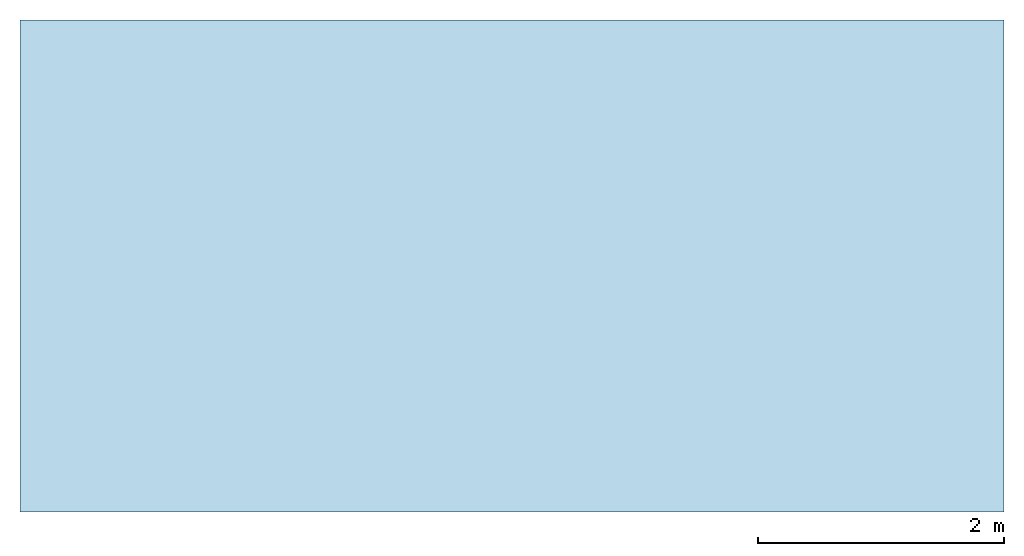
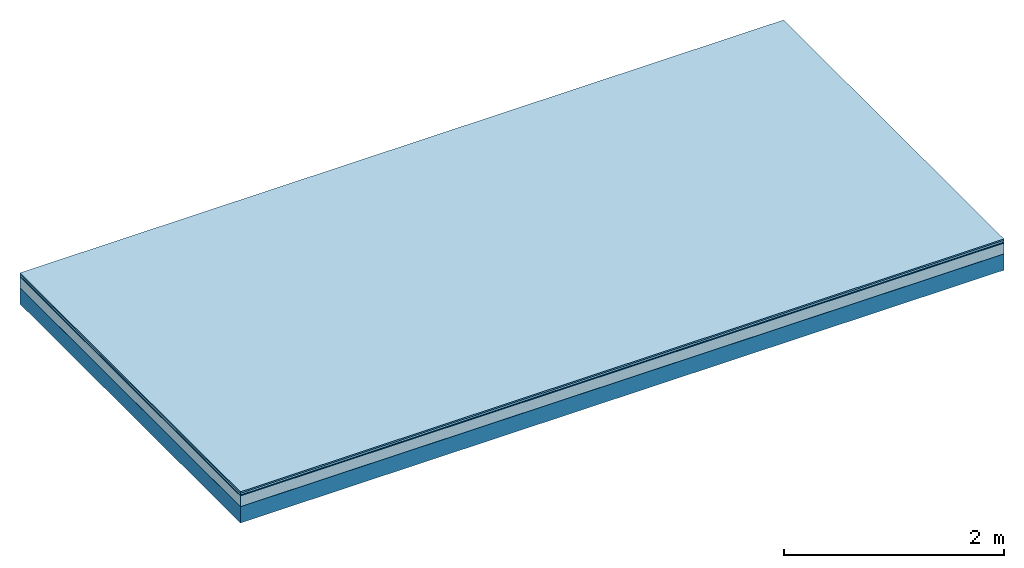
# One storey: 5 plates, 1 member, 1 element without a shape of its own.
"""IFC4 building model written with IfcOpenShell, lengths in metres."""

from ifc_helpers import new_model, si_unit, derived_unit, direction, frame, frame_2d, origin, origin_with_axes, place, context, project, spatial, rectangle, extrude, material, layer, layer_set, type_object, element, aggregate, save


model = new_model("IFC4")

# Units and contexts
plan_context = context("Plan", 3, precision=1e-05, world=origin(), true_north=direction((0.0, 1.0)))
model_context = context("Model", 3, precision=1e-05, world=origin(), true_north=direction((0.0, 1.0)))
ifc_project = project(units=[si_unit("LENGTHUNIT", "METRE"), derived_unit("SOUNDPRESSUREUNIT", [(si_unit("PRESSUREUNIT", "PASCAL", prefix="MICRO"), 0)]), si_unit("ENERGYUNIT", "JOULE", prefix="MEGA"), si_unit("MASSUNIT", "GRAM", prefix="KILO"), derived_unit("THERMALTRANSMITTANCEUNIT", [(si_unit("POWERUNIT", "WATT"), 1), (si_unit("AREAUNIT", "SQUARE_METRE"), -1), (si_unit("THERMODYNAMICTEMPERATUREUNIT", "KELVIN"), -1)]), derived_unit("AREADENSITYUNIT", [(si_unit("MASSUNIT", "GRAM", prefix="KILO"), 1), (si_unit("AREAUNIT", "SQUARE_METRE"), -1)]), derived_unit("USERDEFINED", [(si_unit("ENERGYUNIT", "JOULE", prefix="MEGA"), 1), (si_unit("AREAUNIT", "SQUARE_METRE"), -1)])], contexts=[plan_context, model_context])

# Site, building, storey
site = spatial("IfcSite", under=ifc_project)
building_placement = place(None, origin())
building = spatial("IfcBuilding", under=site, at=building_placement)
storey_placement = place(building_placement, origin())
storey = spatial("IfcBuildingStorey", under=building, at=storey_placement)

# Slab, member, plates
ifc_material_1 = material(Category="11.013")
ifc_layer_1 = layer(ifc_material_1, 0.015, Name="Flooring")
ifc_material_2 = material(Category="03.007")
ifc_layer_2 = layer(ifc_material_2, 0.02, Name="On-material")
ifc_material_3 = material(Name="Wood fiber generic product", Category="10.009")
ifc_layer_3 = layer(ifc_material_3, 0.01, Name="Impact sound insulation")
ifc_material_4 = material(Category="03.011")
ifc_layer_4 = layer(ifc_material_4, 0.12, Name="on Supporting structure")
ifc_material_5 = material(Name="protection", Category="09.007")
ifc_layer_5 = layer(ifc_material_5, 0.0005, Name="Sub-floor")
ifc_material_6 = material(Name="no composite action")
ifc_layer_6 = layer(ifc_material_6, 0.0, Name="Bond")
ifc_layer_7 = layer(None, 0.18, Name="Supporting structure")
ifc_layer_set = layer_set([ifc_layer_1, ifc_layer_2, ifc_layer_3, ifc_layer_4, ifc_layer_5, ifc_layer_6, ifc_layer_7])
slab_type = type_object("IfcSlabType", Name="A2054", PredefinedType="NOTDEFINED", material=ifc_layer_set)
slab_placement = place(None, frame((0.0, 0.0, 0.0), z_axis=(0.0, 0.0, -1.0), x_axis=(1.0, 0.0, 0.0)))
slab = element("IfcSlab", 1, at=slab_placement, inside=storey, type_object=slab_type, material=ifc_layer_set, Name="Slab #1")
ifc_material_7 = material(Name="Solid timber panel")
member_placement = place(slab_placement, origin())
member = element("IfcMember", 2, at=member_placement, material=ifc_material_7, Name="Supporting structure", context=plan_context, shape_type="SweptSolid", body=[
    extrude(rectangle(XDim=1.0, YDim=0.18, at=frame_2d((0.5, 0.09), x_axis=(1.0, 0.0))), frame((0.0, 4.0, 0.1655), z_axis=(0.0, -1.0, 0.0), x_axis=(1.0, 0.0, 0.0)), (0.0, 0.0, 1.0), 4.0),
    extrude(rectangle(XDim=1.0, YDim=0.18, at=frame_2d((0.5, 0.09), x_axis=(1.0, 0.0))), frame((1.0, 4.0, 0.1655), z_axis=(0.0, -1.0, 0.0), x_axis=(1.0, 0.0, 0.0)), (0.0, 0.0, 1.0), 4.0),
    extrude(rectangle(XDim=1.0, YDim=0.18, at=frame_2d((0.5, 0.09), x_axis=(1.0, 0.0))), frame((2.0, 4.0, 0.1655), z_axis=(0.0, -1.0, 0.0), x_axis=(1.0, 0.0, 0.0)), (0.0, 0.0, 1.0), 4.0),
    extrude(rectangle(XDim=1.0, YDim=0.18, at=frame_2d((0.5, 0.09), x_axis=(1.0, 0.0))), frame((3.0, 4.0, 0.1655), z_axis=(0.0, -1.0, 0.0), x_axis=(1.0, 0.0, 0.0)), (0.0, 0.0, 1.0), 4.0),
    extrude(rectangle(XDim=1.0, YDim=0.18, at=frame_2d((0.5, 0.09), x_axis=(1.0, 0.0))), frame((4.0, 4.0, 0.1655), z_axis=(0.0, -1.0, 0.0), x_axis=(1.0, 0.0, 0.0)), (0.0, 0.0, 1.0), 4.0),
    extrude(rectangle(XDim=1.0, YDim=0.18, at=frame_2d((0.5, 0.09), x_axis=(1.0, 0.0))), frame((5.0, 4.0, 0.1655), z_axis=(0.0, -1.0, 0.0), x_axis=(1.0, 0.0, 0.0)), (0.0, 0.0, 1.0), 4.0),
    extrude(rectangle(XDim=1.0, YDim=0.18, at=frame_2d((0.5, 0.09), x_axis=(1.0, 0.0))), frame((6.0, 4.0, 0.1655), z_axis=(0.0, -1.0, 0.0), x_axis=(1.0, 0.0, 0.0)), (0.0, 0.0, 1.0), 4.0),
    extrude(rectangle(XDim=1.0, YDim=0.18, at=frame_2d((0.5, 0.09), x_axis=(1.0, 0.0))), frame((7.0, 4.0, 0.1655), z_axis=(0.0, -1.0, 0.0), x_axis=(1.0, 0.0, 0.0)), (0.0, 0.0, 1.0), 4.0),
])
plate_1_placement = place(slab_placement, origin())
plate_1 = element("IfcPlate", 3, at=plate_1_placement, material=ifc_material_1, Name="Flooring", context=plan_context, shape_type="SweptSolid", body=[
    extrude(rectangle(XDim=8.0, YDim=4.0, at=frame_2d((4.0, 2.0), x_axis=(1.0, 0.0))), origin_with_axes(), (0.0, 0.0, 1.0), 0.015),
])
plate_2_placement = place(slab_placement, origin())
plate_2 = element("IfcPlate", 4, at=plate_2_placement, material=ifc_material_2, Name="On-material", context=plan_context, shape_type="SweptSolid", body=[
    extrude(rectangle(XDim=8.0, YDim=4.0, at=frame_2d((4.0, 2.0), x_axis=(1.0, 0.0))), frame((0.0, 0.0, 0.015), z_axis=(0.0, 0.0, 1.0), x_axis=(1.0, 0.0, 0.0)), (0.0, 0.0, 1.0), 0.02),
])
plate_3_placement = place(slab_placement, origin())
plate_3 = element("IfcPlate", 5, at=plate_3_placement, material=ifc_material_3, Name="Impact sound insulation", context=plan_context, shape_type="SweptSolid", body=[
    extrude(rectangle(XDim=8.0, YDim=4.0, at=frame_2d((4.0, 2.0), x_axis=(1.0, 0.0))), frame((0.0, 0.0, 0.035), z_axis=(0.0, 0.0, 1.0), x_axis=(1.0, 0.0, 0.0)), (0.0, 0.0, 1.0), 0.01),
])
plate_4_placement = place(slab_placement, origin())
plate_4 = element("IfcPlate", 6, at=plate_4_placement, material=ifc_material_4, Name="on Supporting structure", context=plan_context, shape_type="SweptSolid", body=[
    extrude(rectangle(XDim=8.0, YDim=4.0, at=frame_2d((4.0, 2.0), x_axis=(1.0, 0.0))), frame((0.0, 0.0, 0.045), z_axis=(0.0, 0.0, 1.0), x_axis=(1.0, 0.0, 0.0)), (0.0, 0.0, 1.0), 0.12),
])
plate_5_placement = place(slab_placement, origin())
plate_5 = element("IfcPlate", 7, at=plate_5_placement, material=ifc_material_5, Name="Sub-floor", context=plan_context, shape_type="SweptSolid", body=[
    extrude(rectangle(XDim=8.0, YDim=4.0, at=frame_2d((4.0, 2.0), x_axis=(1.0, 0.0))), frame((0.0, 0.0, 0.165), z_axis=(0.0, 0.0, 1.0), x_axis=(1.0, 0.0, 0.0)), (0.0, 0.0, 1.0), 0.0005),
])
aggregate(slab, [plate_1, plate_2, plate_3, plate_4, plate_5, member])

save(model, "model.ifc")
